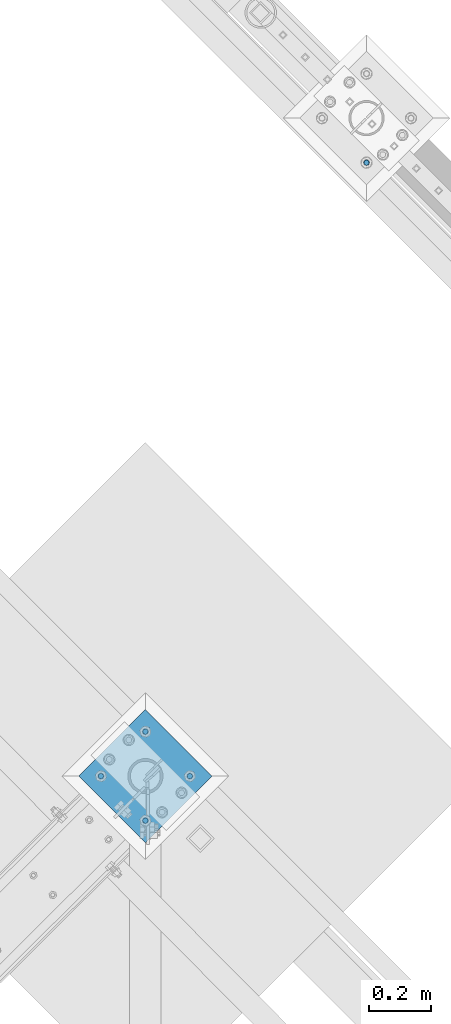
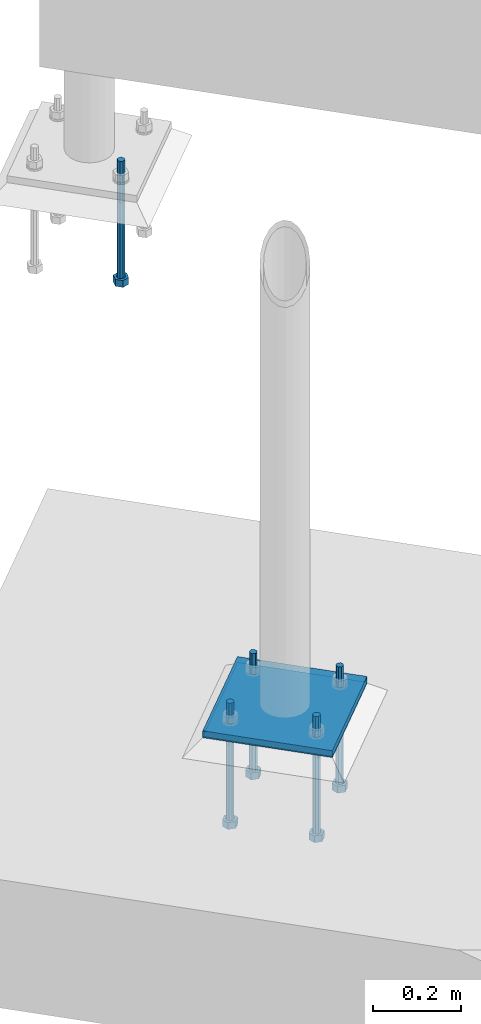
# One storey, part 527 of 975: 7 beams.
"""IFC2X3 building model written with IfcOpenShell, lengths in millimetres."""

import ifcopenshell
import ifcopenshell.guid

model = None  # the IFC model being written
_history = None  # IfcOwnerHistory: only IFC2X3 demands one
_inside = {}  # id of a spatial element -> (the spatial element, [elements in it])
_under = {}  # id of a project, library or spatial element -> (it, [spatial elements below it])
_declared = {}  # id of a project -> (the project, [libraries it declares])
_typed = {}  # id of a type object -> (the type object, [elements of that type])
_made_of = {}  # id of a material, layer set ... -> (it, [elements and type objects made of it])


def new_model(schema):
    """Start an empty IFC model of exactly this schema.

    Asked for "IFC4X3", IfcOpenShell would pick the latest addendum, in which some entities
    have other attributes; the version numbers below select the first issue.
    IFC2X3 requires an IfcOwnerHistory on every rooted entity: one is made here for all.
    """
    global model, _history
    if schema == "IFC4X3":
        model = ifcopenshell.file(schema_version=(4, 3, 0, 0))
    else:
        model = ifcopenshell.file(schema=schema)
    _inside.clear()
    _under.clear()
    _declared.clear()
    _typed.clear()
    _made_of.clear()
    _history = None
    if model.schema == "IFC2X3":
        org = make("IfcOrganization", Name="unknown")
        user = make(
            "IfcPersonAndOrganization",
            ThePerson=make("IfcPerson", FamilyName="unknown"),
            TheOrganization=org,
        )
        app = make(
            "IfcApplication",
            ApplicationDeveloper=org,
            Version="unknown",
            ApplicationFullName="unknown",
            ApplicationIdentifier="unknown",
        )
        _history = make(
            "IfcOwnerHistory",
            OwningUser=user,
            OwningApplication=app,
            ChangeAction="ADDED",
            CreationDate=0,
        )
    return model


def make(cls, **values):
    """One entity of the class cls with the attributes given. An attribute that is None is left unset."""
    return model.create_entity(
        cls, **{name: value for name, value in values.items() if value is not None}
    )


def rooted(cls, **values):
    """An entity with a GlobalId (a new one), such as an element, a storey or a relation."""
    return make(cls, GlobalId=ifcopenshell.guid.new(), OwnerHistory=_history, **values)


def si_unit(unit_type, name, prefix=None):
    """IfcSIUnit, for example si_unit("LENGTHUNIT", "METRE", prefix="MILLI")."""
    return make("IfcSIUnit", UnitType=unit_type, Prefix=prefix, Name=name)


def assignment(units):
    """IfcUnitAssignment: the units of a project."""
    return None if units is None else make("IfcUnitAssignment", Units=units)


def point(xyz):
    """IfcCartesianPoint."""
    return None if xyz is None else make("IfcCartesianPoint", Coordinates=xyz)


def direction(xyz):
    """IfcDirection."""
    return None if xyz is None else make("IfcDirection", DirectionRatios=xyz)


def frame(location, z_axis=None, x_axis=None):
    """IfcAxis2Placement3D, a coordinate frame: its origin and axes. An axis left out is left unset."""
    return make(
        "IfcAxis2Placement3D",
        Location=point(location),
        Axis=direction(z_axis),
        RefDirection=direction(x_axis),
    )


def origin_with_axes():
    """The frame at (0, 0, 0) with the z axis (0, 0, 1) and the x axis (1, 0, 0) written out."""
    return frame((0.0, 0.0, 0.0), z_axis=(0.0, 0.0, 1.0), x_axis=(1.0, 0.0, 0.0))


def place(relative_to, where):
    """IfcLocalPlacement: puts the frame where relative to a parent placement (None: the world)."""
    return make(
        "IfcLocalPlacement", PlacementRelTo=relative_to, RelativePlacement=where
    )


def context(
    kind, dimensions, precision=None, world=None, true_north=None, identifier=None
):
    """IfcGeometricRepresentationContext, for example the 3D "Model" context."""
    return make(
        "IfcGeometricRepresentationContext",
        ContextIdentifier=identifier,
        ContextType=kind,
        CoordinateSpaceDimension=dimensions,
        Precision=precision,
        WorldCoordinateSystem=world,
        TrueNorth=true_north,
    )


def subcontext(parent, identifier, kind, view, scale=None):
    """IfcGeometricRepresentationSubContext, for example "Body" below "Model"."""
    return make(
        "IfcGeometricRepresentationSubContext",
        ContextIdentifier=identifier,
        ContextType=kind,
        ParentContext=parent,
        TargetScale=scale,
        TargetView=view,
    )


def project(units=None, contexts=None):
    """IfcProject with its units and contexts."""
    return rooted(
        "IfcProject",
        Name="project",
        RepresentationContexts=contexts,
        UnitsInContext=assignment(units),
    )


def spatial(cls, under=None, at=None, **own):
    """A site, building, storey or space (cls), placed at a placement, below another one or the project."""
    s = rooted(cls, ObjectPlacement=at, **own)
    if under is not None:
        _under.setdefault(under.id(), (under, []))[1].append(s)
    return s


def faces_of(points, faces, orient=None, outer=None):
    """IfcFace entities. A face is a list of loops; a loop is a list of indices into points, from 0.

    orient and outer hold one flag for each loop. By default every Orientation is true, the
    first loop of a face is its IfcFaceOuterBound and the others are IfcFaceBound.
    """
    made = []
    for i, loops in enumerate(faces):
        bounds = []
        for j, loop in enumerate(loops):
            is_outer = j == 0 if outer is None else outer[i][j]
            bounds.append(
                make(
                    "IfcFaceOuterBound" if is_outer else "IfcFaceBound",
                    Bound=make("IfcPolyLoop", Polygon=[points[k] for k in loop]),
                    Orientation=True if orient is None else orient[i][j],
                )
            )
        made.append(make("IfcFace", Bounds=bounds))
    return made


def faceted_brep(points, faces, orient=None, outer=None, voids=None):
    """IfcFacetedBrep: a solid bounded by flat faces; with voids (closed shells), ...WithVoids."""
    shared = [point(p) for p in points]
    hull = make("IfcClosedShell", CfsFaces=faces_of(shared, faces, orient, outer))
    if voids is None:
        return make("IfcFacetedBrep", Outer=hull)
    return make(
        "IfcFacetedBrepWithVoids",
        Outer=hull,
        Voids=[
            make(cls, CfsFaces=faces_of(shared, fs, o, b)) for cls, fs, o, b in voids
        ],
    )


def shape(context_of_items, identifier, shape_type, items):
    """IfcShapeRepresentation: the items that make up one representation, for example the "Body"."""
    return make(
        "IfcShapeRepresentation",
        ContextOfItems=context_of_items,
        RepresentationIdentifier=identifier,
        RepresentationType=shape_type,
        Items=items,
    )


def material(Name=None, Category=None):
    """IfcMaterial."""
    return make("IfcMaterial", Name=Name, Category=Category)


def made_of(thing, what):
    """Note that an element or type object is made of a material, layer set ...; save() writes the relation."""
    if what is not None:
        _made_of.setdefault(what.id(), (what, []))[1].append(thing)
    return thing


def type_object(cls, material=None, **own):
    """A type object (cls), such as IfcWallType, which elements share."""
    return made_of(rooted(cls, **own), material)


def element(
    cls,
    number,
    at=None,
    inside=None,
    cuts=None,
    type_object=None,
    material=None,
    context=None,
    identifier="Body",
    shape_type=None,
    held_by="IfcProductDefinitionShape",
    body=None,
    shapes=None,
    **own,
):
    """One element of the class cls, such as IfcWall. Its Tag is "e" and its number.

    at: its placement. inside: the storey or other place that contains it. cuts: it is an
    opening in that element (IfcRelVoidsElement). A single representation is given by context,
    identifier, shape_type and body (its items); several are given by shapes. held_by: the class
    of the entity that holds the representations. save() writes the other relations.
    """
    e = rooted(cls, Tag="e%d" % number, ObjectPlacement=at, **own)
    if body is not None:
        shapes = [shape(context, identifier, shape_type, body)]
    if shapes is not None:
        e.Representation = make(held_by, Representations=shapes)
    if inside is not None:
        _inside.setdefault(inside.id(), (inside, []))[1].append(e)
    if cuts is not None:
        rooted(
            "IfcRelVoidsElement", RelatingBuildingElement=cuts, RelatedOpeningElement=e
        )
    if type_object is not None:
        _typed.setdefault(type_object.id(), (type_object, []))[1].append(e)
    return made_of(e, material)


def aggregate(whole, parts):
    """IfcRelAggregates: a whole, such as a stair, and the parts it consists of."""
    return rooted("IfcRelAggregates", RelatingObject=whole, RelatedObjects=parts)


def save(model, path):
    """Write the relations noted so far, then the file.

    IfcRelAggregates (storeys below a building ...), IfcRelContainedInSpatialStructure (elements
    in a storey), IfcRelDefinesByType, IfcRelAssociatesMaterial and IfcRelDeclares: one each for
    every whole, place, type object, material and project.
    """
    for whole, parts in _under.values():
        aggregate(whole, parts)
    for where, things in _inside.values():
        rooted(
            "IfcRelContainedInSpatialStructure",
            RelatedElements=things,
            RelatingStructure=where,
        )
    for kind, things in _typed.values():
        rooted("IfcRelDefinesByType", RelatedObjects=things, RelatingType=kind)
    for what, things in _made_of.values():
        rooted("IfcRelAssociatesMaterial", RelatedObjects=things, RelatingMaterial=what)
    for by, libraries in _declared.values():
        rooted("IfcRelDeclares", RelatingContext=by, RelatedDefinitions=libraries)
    model.write(path)


model = new_model("IFC2X3")

# Units and contexts
model_context = context("Model", 3, precision=1e-05, world=origin_with_axes())
body_context = subcontext(model_context, "Body", "Model", "MODEL_VIEW")
ifc_project = project(units=[si_unit("LENGTHUNIT", "METRE", prefix="MILLI"), si_unit("AREAUNIT", "SQUARE_METRE"), si_unit("VOLUMEUNIT", "CUBIC_METRE"), si_unit("MASSUNIT", "GRAM", prefix="KILO"), si_unit("TIMEUNIT", "SECOND"), si_unit("PLANEANGLEUNIT", "RADIAN"), si_unit("SOLIDANGLEUNIT", "STERADIAN"), si_unit("THERMODYNAMICTEMPERATUREUNIT", "DEGREE_CELSIUS"), si_unit("LUMINOUSINTENSITYUNIT", "LUMEN")], contexts=[model_context])

# Site, building, storey
site_placement = place(None, origin_with_axes())
site = spatial("IfcSite", under=ifc_project, at=site_placement, CompositionType="ELEMENT")
building_placement = place(site_placement, origin_with_axes())
building = spatial("IfcBuilding", under=site, at=building_placement, Name="Undefined", CompositionType="ELEMENT")
storey_placement = place(building_placement, origin_with_axes())
storey = spatial("IfcBuildingStorey", under=building, at=storey_placement, Name="Undefined", CompositionType="ELEMENT", Elevation=0.0)

# Beams
ifc_material_1 = material(Name="STEEL/A36")
beam_type_1 = type_object("IfcBeamType", PredefinedType="NOTDEFINED")
beam_1_placement = place(storey_placement, frame((29940.0630734527, 15856.1369265472, -257.175000000002), z_axis=(-0.707106781186548, -0.707106781186548, 0.0), x_axis=(-0.707106781186601, 0.707106781186494, 2.36468622460961e-14)))
element("IfcBeam", 1, at=beam_1_placement, inside=storey, type_object=beam_type_1, material=ifc_material_1, Name="PLATE", context=body_context, shape_type="Brep", body=[
    faceted_brep([(0.0, 9.52499999999964, -152.4), (0.0, 9.52499999999964, 152.4), (304.799999999152, 9.52499999999964, 152.4), (304.799999999152, 9.52499999999964, -152.4), (0.0, -9.52499999999964, 152.4), (304.799999999152, -9.52499999999964, 152.4), (0.0, -9.52499999999964, -152.4), (304.799999999152, -9.52499999999964, -152.4)], [[[0, 1, 2, 3]], [[1, 4, 5, 2]], [[4, 6, 7, 5]], [[6, 0, 3, 7]], [[5, 7, 3, 2]], [[6, 4, 1, 0]]]),
])
ifc_material_2 = material(Name="STEEL/F1554-36")
beam_type_2 = type_object("IfcBeamType", PredefinedType="NOTDEFINED")
beam_2_placement = place(storey_placement, frame((30546.675001079, 17945.8784053001, -304.799999999999), z_axis=(0.707106781186548, 0.707106781186548, 0.0), x_axis=(0.0, 0.0, -1.0)))
element("IfcBeam", 2, at=beam_2_placement, inside=storey, type_object=beam_type_2, material=ifc_material_2, Name="HEADED_ANCHOR_BOLT", context=body_context, shape_type="Brep", body=[
    faceted_brep([(209.543749999999, -9.13000011446275, 15.8100004196049), (209.543749999999, -18.2600002288382, 4.72937244921923e-11), (228.593749999998, -18.2600002288382, 4.72937244921923e-11), (228.593749999998, -9.13000011446275, 15.8100004196049), (209.543749999999, 9.13000011438271, 15.8100004195576), (228.593749999998, 9.13000011438271, 15.8100004195576), (209.543749999999, 18.2600002288382, -4.72937244921923e-11), (228.593749999998, 18.2600002288382, -4.72937244921923e-11), (209.543749999999, 9.13000011446275, -15.8100004196049), (228.593749999998, 9.13000011446275, -15.8100004196049), (209.543749999999, -9.13000011438271, -15.8100004195576), (228.593749999998, -9.13000011438271, -15.8100004195576), (209.543749999999, -4.4776800552936, 9.29799844178979), (209.543749999999, -8.068500660469, 6.43441456491473), (209.543749999999, -10.0612557561763, 2.2964159705416), (209.543749999999, -10.0612557561617, -2.29641597048976), (209.543749999999, -8.0685006604399, -6.4344145648729), (209.543749999999, -4.47768005524995, -9.29799844176705), (209.543749999999, 2.91038304567337e-11, -10.3199996948015), (209.543749999999, 4.4776800552936, -9.29799844178979), (209.543749999999, 8.068500660469, -6.43441456491473), (209.543749999999, 10.0612557561763, -2.2964159705416), (209.543749999999, 10.0612557561617, 2.29641597048976), (209.543749999999, 8.0685006604399, 6.4344145648729), (209.543749999999, 4.47768005524995, 9.29799844176705), (209.543749999999, -2.91038304567337e-11, 10.3199996948015), (228.593749999998, -2.91038304567337e-11, 10.3199996948015), (228.593749999998, -4.4776800552936, 9.29799844178979), (228.593749999998, -8.068500660469, 6.43441456491473), (228.593749999998, -10.0612557561763, 2.2964159705416), (228.593749999998, -10.0612557561617, -2.29641597048976), (228.593749999998, -8.0685006604399, -6.4344145648729), (228.593749999998, -4.47768005524995, -9.29799844176705), (228.593749999998, 2.91038304567337e-11, -10.3199996948015), (228.593749999998, 4.4776800552936, -9.29799844178979), (228.593749999998, 8.068500660469, -6.43441456491473), (228.593749999998, 10.0612557561763, -2.2964159705416), (228.593749999998, 10.0612557561617, 2.29641597048976), (228.593749999998, 8.0685006604399, 6.4344145648729), (228.593749999998, 4.47768005524995, 9.29799844176705), (0.0, -6.73519209080223, 6.73519209080186), (0.0, -9.52499999999964, 0.0), (228.6, -9.52500000000146, 0.0), (228.6, -6.73519209080405, 6.73519209080223), (-9.87109982941227e-13, -1.20792265079217e-13, 9.52499961853027), (228.6, 0.0, 9.52499999999964), (0.0, 6.73519209080223, 6.73519209080186), (228.6, 6.73519209080405, 6.73519209080223), (0.0, 9.52499999999964, 0.0), (228.6, 9.52500000000146, 0.0), (0.0, 6.73519209080223, -6.73519209080186), (228.6, 6.73519209080405, -6.73519209080223), (2.95075507493764e-12, -1.20792265079217e-13, -9.52499961853027), (228.6, 0.0, -9.52499999999964), (-114.297914995421, -6.36396103067818, 6.36396103068091), (-114.297914995421, -2.18278728425503e-11, 8.99999999997999), (-114.297914995421, 6.36396103064908, 6.36396103064817), (-114.297914995421, 8.99999999997817, -2.27373675443232e-11), (-114.297914995421, 6.36396103067818, -6.36396103068091), (-114.297914995421, 2.18278728425503e-11, -8.99999999997999), (-114.297914995421, -6.36396103064908, -6.36396103064817), (-114.297914995421, -8.99999999997817, 2.27373675443232e-11), (0.0149743263646087, 6.36396103067818, -6.36396103067909), (0.0149743263646087, 0.0, -9.0), (0.0149743263646087, -6.36396103067818, -6.36396103067909), (0.0149743263987148, -8.9999995411581, -1.00796984270346e-06), (0.0149743263646087, -6.36396103067818, 6.36396103067909), (0.0149743263646087, 0.0, 9.0), (0.0149743263646087, 6.36396103067818, 6.36396103067909), (0.0149743263987148, 9.0000004588419, -1.00796984270346e-06), (0.0, -6.73519209080223, -6.73519209080186), (228.6, -6.73519209080405, -6.73519209080223)], [[[0, 1, 2, 3]], [[4, 0, 3, 5]], [[6, 4, 5, 7]], [[8, 6, 7, 9]], [[10, 8, 9, 11]], [[0, 4, 6, 8, 10, 1], [12, 13, 14, 15, 16, 17, 18, 19, 20, 21, 22, 23, 24, 25]], [[12, 25, 26, 27]], [[13, 12, 27, 28]], [[14, 13, 28, 29]], [[15, 14, 29, 30]], [[16, 15, 30, 31]], [[17, 16, 31, 32]], [[18, 17, 32, 33]], [[19, 18, 33, 34]], [[20, 19, 34, 35]], [[21, 20, 35, 36]], [[22, 21, 36, 37]], [[23, 22, 37, 38]], [[24, 23, 38, 39]], [[25, 24, 39, 26]], [[9, 7, 5, 3, 2, 11], [38, 37, 36, 35, 34, 33, 32, 31, 30, 29, 28, 27, 26, 39]], [[1, 10, 11, 2]], [[40, 41, 42, 43]], [[44, 40, 43, 45]], [[46, 44, 45, 47]], [[48, 46, 47, 49]], [[50, 48, 49, 51]], [[52, 50, 51, 53]], [[54, 55, 56, 57, 58, 59, 60, 61]], [[59, 58, 62, 63]], [[60, 59, 63, 64]], [[61, 60, 64, 65]], [[54, 61, 65, 66]], [[55, 54, 66, 67]], [[56, 55, 67, 68]], [[57, 56, 68, 69]], [[58, 57, 69, 62]], [[40, 44, 46, 48, 50, 52, 70, 41], [68, 67, 66, 65, 64, 63, 62, 69]], [[41, 70, 71, 42]], [[53, 51, 49, 47, 45, 43, 42, 71]], [[70, 52, 53, 71]]]),
])
beam_3_placement = place(storey_placement, frame((29832.300001079, 16107.5840947003, -304.794708331233), z_axis=(-0.707106781186601, 0.707106781186494, 2.36468622460961e-14), x_axis=(0.0, 0.0, -1.0)))
element("IfcBeam", 3, at=beam_3_placement, inside=storey, type_object=beam_type_2, material=ifc_material_2, Name="HEADED_ANCHOR_BOLT", context=body_context, shape_type="Brep", body=[
    faceted_brep([(210.349041668767, -9.13000011445183, 15.8100004196131), (210.349041668767, -18.2600002288636, 2.5465851649642e-11), (229.399041668767, -18.2600002288636, 2.5465851649642e-11), (229.399041668767, -9.13000011445183, 15.8100004196131), (210.349041668767, 9.13000011440818, 15.8100004195894), (229.399041668767, 9.13000011440818, 15.8100004195894), (210.349041668767, 18.26000022886, -2.18278728425503e-11), (229.399041668767, 18.26000022886, -2.18278728425503e-11), (210.349041668767, 9.13000011444819, -15.8100004196076), (229.399041668767, 9.13000011444819, -15.8100004196076), (210.349041668767, -9.13000011441545, -15.8100004195876), (229.399041668767, -9.13000011441545, -15.8100004195876), (210.349041668767, -4.47768005528997, 9.29799844179615), (210.349041668767, -8.06850066047264, 6.43441456491382), (210.349041668767, -10.0612557561872, 2.2964159705316), (210.349041668767, -10.0612557561799, -2.29641597050431), (210.349041668767, -8.06850066045808, -6.43441456488472), (210.349041668767, -4.47768005526814, -9.2979984417816), (210.349041668767, 1.09139364212751e-11, -10.3199996948097), (210.349041668767, 4.47768005528997, -9.29799844179433), (210.349041668767, 8.06850066047264, -6.43441456491018), (210.349041668767, 10.0612557561799, -2.29641597052978), (210.349041668767, 10.0612557561763, 2.29641597051159), (210.349041668767, 8.06850066045808, 6.43441456489199), (210.349041668767, 4.47768005526086, 9.29799844178342), (210.349041668767, -1.09139364212751e-11, 10.3199996948151), (229.399041668767, -1.09139364212751e-11, 10.3199996948151), (229.399041668767, -4.47768005528997, 9.29799844179615), (229.399041668767, -8.06850066047264, 6.43441456491382), (229.399041668767, -10.0612557561872, 2.2964159705316), (229.399041668767, -10.0612557561799, -2.29641597050431), (229.399041668767, -8.06850066045808, -6.43441456488472), (229.399041668767, -4.47768005526814, -9.2979984417816), (229.399041668767, 1.09139364212751e-11, -10.3199996948097), (229.399041668767, 4.47768005528997, -9.29799844179433), (229.399041668767, 8.06850066047264, -6.43441456491018), (229.399041668767, 10.0612557561799, -2.29641597052978), (229.399041668767, 10.0612557561763, 2.29641597051159), (229.399041668767, 8.06850066045808, 6.43441456489199), (229.399041668767, 4.47768005526086, 9.29799844178342), (0.0, -6.73519209080223, 6.73519209080186), (0.0, -9.52499999999964, 0.0), (228.605291668766, -9.52499999999054, 1.45519152283669e-11), (228.605291668766, -6.73519209080405, 6.73519209080405), (-9.87109982941227e-13, -1.20792265079217e-13, 9.52499961853027), (228.605291668766, -1.09139364212751e-11, 9.52499999999054), (0.0, 6.73519209080223, 6.73519209080186), (228.605291668766, 6.73519209078586, 6.73519209078768), (0.0, 9.52499999999964, 0.0), (228.605291668766, 9.52499999999054, -9.09494701772928e-12), (0.0, 6.73519209080223, -6.73519209080186), (228.605291668766, 6.73519209080041, -6.73519209080223), (2.95075507493764e-12, -1.20792265079217e-13, -9.52499961853027), (228.605291668766, 1.09139364212751e-11, -9.52499999998508), (-114.294672089865, -6.36396103028892, 6.36396103068546), (-114.29460082623, -1.09139364212751e-11, 8.99999999999091), (-114.294529562594, 6.36396103026709, 6.36396103066909), (-114.29450004423, 8.99999999943611, -9.09494701772928e-12), (-114.294529562594, 6.36396103028528, -6.36396103067455), (-114.29460082623, 1.09139364212751e-11, -8.99999999998909), (-114.294672089865, -6.36396103027437, -6.36396103066363), (-114.29470160823, -8.99999999943611, 1.45519152283669e-11), (0.00536293275933986, 6.36268110000674, -6.36396103067818), (0.00529166912366463, -0.00127993026762852, -8.99999999998545), (0.00522040548793257, -6.36524096055291, -6.36396103066181), (0.00519088712354687, -9.00127992971102, 1.45519152283669e-11), (0.00522040548793257, -6.36524096056746, 6.36396103068182), (0.00529166912366463, -0.00127993029309437, 8.99999999999454), (0.00536293275933986, 6.36268109998855, 6.36396103066545), (0.00539245112372555, 8.99872006915029, -9.09494701772928e-12), (0.0, -6.73519209080223, -6.73519209080186), (228.605291668766, -6.73519209078586, -6.7351920907804)], [[[0, 1, 2, 3]], [[4, 0, 3, 5]], [[6, 4, 5, 7]], [[8, 6, 7, 9]], [[10, 8, 9, 11]], [[0, 4, 6, 8, 10, 1], [12, 13, 14, 15, 16, 17, 18, 19, 20, 21, 22, 23, 24, 25]], [[12, 25, 26, 27]], [[13, 12, 27, 28]], [[14, 13, 28, 29]], [[15, 14, 29, 30]], [[16, 15, 30, 31]], [[17, 16, 31, 32]], [[18, 17, 32, 33]], [[19, 18, 33, 34]], [[20, 19, 34, 35]], [[21, 20, 35, 36]], [[22, 21, 36, 37]], [[23, 22, 37, 38]], [[24, 23, 38, 39]], [[25, 24, 39, 26]], [[9, 7, 5, 3, 2, 11], [38, 37, 36, 35, 34, 33, 32, 31, 30, 29, 28, 27, 26, 39]], [[1, 10, 11, 2]], [[40, 41, 42, 43]], [[44, 40, 43, 45]], [[46, 44, 45, 47]], [[48, 46, 47, 49]], [[50, 48, 49, 51]], [[52, 50, 51, 53]], [[54, 55, 56, 57, 58, 59, 60, 61]], [[59, 58, 62, 63]], [[60, 59, 63, 64]], [[61, 60, 64, 65]], [[54, 61, 65, 66]], [[55, 54, 66, 67]], [[56, 55, 67, 68]], [[57, 56, 68, 69]], [[58, 57, 69, 62]], [[40, 44, 46, 48, 50, 52, 70, 41], [68, 67, 66, 65, 64, 63, 62, 69]], [[41, 70, 71, 42]], [[53, 51, 49, 47, 45, 43, 42, 71]], [[70, 52, 53, 71]]]),
])
beam_4_placement = place(storey_placement, frame((29688.6159053001, 15963.899998921, -304.794708331233), z_axis=(0.707106781186513, -0.707106781186582, 3.1377567211166e-14), x_axis=(0.0, 0.0, -1.0)))
element("IfcBeam", 4, at=beam_4_placement, inside=storey, type_object=beam_type_2, material=ifc_material_2, Name="HEADED_ANCHOR_BOLT", context=body_context, shape_type="Brep", body=[
    faceted_brep([(210.349041668767, -9.13000011445183, 15.8100004196131), (210.349041668767, -18.2600002288636, 2.5465851649642e-11), (229.399041668767, -18.2600002288636, 2.5465851649642e-11), (229.399041668767, -9.13000011445183, 15.8100004196131), (210.349041668767, 9.13000011440818, 15.8100004195894), (229.399041668767, 9.13000011440818, 15.8100004195894), (210.349041668767, 18.26000022886, -2.18278728425503e-11), (229.399041668767, 18.26000022886, -2.18278728425503e-11), (210.349041668767, 9.13000011444819, -15.8100004196076), (229.399041668767, 9.13000011444819, -15.8100004196076), (210.349041668767, -9.13000011441545, -15.8100004195876), (229.399041668767, -9.13000011441545, -15.8100004195876), (210.349041668767, -4.47768005528997, 9.29799844179615), (210.349041668767, -8.06850066047264, 6.43441456491382), (210.349041668767, -10.0612557561872, 2.2964159705316), (210.349041668767, -10.0612557561799, -2.29641597050431), (210.349041668767, -8.06850066045808, -6.43441456488472), (210.349041668767, -4.47768005526814, -9.2979984417816), (210.349041668767, 1.09139364212751e-11, -10.3199996948097), (210.349041668767, 4.47768005528997, -9.29799844179433), (210.349041668767, 8.06850066047264, -6.43441456491018), (210.349041668767, 10.0612557561799, -2.29641597052978), (210.349041668767, 10.0612557561763, 2.29641597051159), (210.349041668767, 8.06850066045808, 6.43441456489199), (210.349041668767, 4.47768005526086, 9.29799844178342), (210.349041668767, -1.09139364212751e-11, 10.3199996948151), (229.399041668767, -1.09139364212751e-11, 10.3199996948151), (229.399041668767, -4.47768005528997, 9.29799844179615), (229.399041668767, -8.06850066047264, 6.43441456491382), (229.399041668767, -10.0612557561872, 2.2964159705316), (229.399041668767, -10.0612557561799, -2.29641597050431), (229.399041668767, -8.06850066045808, -6.43441456488472), (229.399041668767, -4.47768005526814, -9.2979984417816), (229.399041668767, 1.09139364212751e-11, -10.3199996948097), (229.399041668767, 4.47768005528997, -9.29799844179433), (229.399041668767, 8.06850066047264, -6.43441456491018), (229.399041668767, 10.0612557561799, -2.29641597052978), (229.399041668767, 10.0612557561763, 2.29641597051159), (229.399041668767, 8.06850066045808, 6.43441456489199), (229.399041668767, 4.47768005526086, 9.29799844178342), (0.0, -6.73519209080223, 6.73519209080186), (0.0, -9.52499999999964, 0.0), (228.605291668766, -9.52499999999054, 1.45519152283669e-11), (228.605291668766, -6.73519209080405, 6.73519209080405), (-9.87109982941227e-13, -1.20792265079217e-13, 9.52499961853027), (228.605291668766, -1.09139364212751e-11, 9.52499999999054), (0.0, 6.73519209080223, 6.73519209080186), (228.605291668766, 6.73519209078586, 6.73519209078768), (0.0, 9.52499999999964, 0.0), (228.605291668766, 9.52499999999054, -9.09494701772928e-12), (0.0, 6.73519209080223, -6.73519209080186), (228.605291668766, 6.73519209080041, -6.73519209080223), (2.95075507493764e-12, -1.20792265079217e-13, -9.52499961853027), (228.605291668766, 1.09139364212751e-11, -9.52499999998508), (-114.294672089865, -6.36396103028892, 6.36396103068546), (-114.29460082623, -1.09139364212751e-11, 8.99999999999091), (-114.294529562594, 6.36396103026709, 6.36396103066909), (-114.29450004423, 8.99999999943611, -9.09494701772928e-12), (-114.294529562594, 6.36396103028528, -6.36396103067455), (-114.29460082623, 1.09139364212751e-11, -8.99999999998909), (-114.294672089865, -6.36396103027437, -6.36396103066363), (-114.29470160823, -8.99999999943611, 1.45519152283669e-11), (0.00536293275933986, 6.36268110000674, -6.36396103067818), (0.00529166912366463, -0.00127993026762852, -8.99999999998545), (0.00522040548793257, -6.36524096055291, -6.36396103066181), (0.00519088712354687, -9.00127992971102, 1.45519152283669e-11), (0.00522040548793257, -6.36524096056746, 6.36396103068182), (0.00529166912366463, -0.00127993029309437, 8.99999999999454), (0.00536293275933986, 6.36268109998855, 6.36396103066545), (0.00539245112372555, 8.99872006915029, -9.09494701772928e-12), (0.0, -6.73519209080223, -6.73519209080186), (228.605291668766, -6.73519209078586, -6.7351920907804)], [[[0, 1, 2, 3]], [[4, 0, 3, 5]], [[6, 4, 5, 7]], [[8, 6, 7, 9]], [[10, 8, 9, 11]], [[0, 4, 6, 8, 10, 1], [12, 13, 14, 15, 16, 17, 18, 19, 20, 21, 22, 23, 24, 25]], [[12, 25, 26, 27]], [[13, 12, 27, 28]], [[14, 13, 28, 29]], [[15, 14, 29, 30]], [[16, 15, 30, 31]], [[17, 16, 31, 32]], [[18, 17, 32, 33]], [[19, 18, 33, 34]], [[20, 19, 34, 35]], [[21, 20, 35, 36]], [[22, 21, 36, 37]], [[23, 22, 37, 38]], [[24, 23, 38, 39]], [[25, 24, 39, 26]], [[9, 7, 5, 3, 2, 11], [38, 37, 36, 35, 34, 33, 32, 31, 30, 29, 28, 27, 26, 39]], [[1, 10, 11, 2]], [[40, 41, 42, 43]], [[44, 40, 43, 45]], [[46, 44, 45, 47]], [[48, 46, 47, 49]], [[50, 48, 49, 51]], [[52, 50, 51, 53]], [[54, 55, 56, 57, 58, 59, 60, 61]], [[59, 58, 62, 63]], [[60, 59, 63, 64]], [[61, 60, 64, 65]], [[54, 61, 65, 66]], [[55, 54, 66, 67]], [[56, 55, 67, 68]], [[57, 56, 68, 69]], [[58, 57, 69, 62]], [[40, 44, 46, 48, 50, 52, 70, 41], [68, 67, 66, 65, 64, 63, 62, 69]], [[41, 70, 71, 42]], [[53, 51, 49, 47, 45, 43, 42, 71]], [[70, 52, 53, 71]]]),
])
beam_5_placement = place(storey_placement, frame((29832.300001079, 15820.2159031418, -304.794708331233), z_axis=(0.707106781186513, -0.707106781186582, 3.1377567211166e-14), x_axis=(0.0, 0.0, -1.0)))
element("IfcBeam", 5, at=beam_5_placement, inside=storey, type_object=beam_type_2, material=ifc_material_2, Name="HEADED_ANCHOR_BOLT", context=body_context, shape_type="Brep", body=[
    faceted_brep([(210.349041668767, -9.13000011445183, 15.8100004196131), (210.349041668767, -18.2600002288636, 2.5465851649642e-11), (229.399041668767, -18.2600002288636, 2.5465851649642e-11), (229.399041668767, -9.13000011445183, 15.8100004196131), (210.349041668767, 9.13000011440818, 15.8100004195894), (229.399041668767, 9.13000011440818, 15.8100004195894), (210.349041668767, 18.26000022886, -2.18278728425503e-11), (229.399041668767, 18.26000022886, -2.18278728425503e-11), (210.349041668767, 9.13000011444819, -15.8100004196076), (229.399041668767, 9.13000011444819, -15.8100004196076), (210.349041668767, -9.13000011441545, -15.8100004195876), (229.399041668767, -9.13000011441545, -15.8100004195876), (210.349041668767, -4.47768005528997, 9.29799844179615), (210.349041668767, -8.06850066047264, 6.43441456491382), (210.349041668767, -10.0612557561872, 2.2964159705316), (210.349041668767, -10.0612557561799, -2.29641597050431), (210.349041668767, -8.06850066045808, -6.43441456488472), (210.349041668767, -4.47768005526814, -9.2979984417816), (210.349041668767, 1.09139364212751e-11, -10.3199996948097), (210.349041668767, 4.47768005528997, -9.29799844179433), (210.349041668767, 8.06850066047264, -6.43441456491018), (210.349041668767, 10.0612557561799, -2.29641597052978), (210.349041668767, 10.0612557561763, 2.29641597051159), (210.349041668767, 8.06850066045808, 6.43441456489199), (210.349041668767, 4.47768005526086, 9.29799844178342), (210.349041668767, -1.09139364212751e-11, 10.3199996948151), (229.399041668767, -1.09139364212751e-11, 10.3199996948151), (229.399041668767, -4.47768005528997, 9.29799844179615), (229.399041668767, -8.06850066047264, 6.43441456491382), (229.399041668767, -10.0612557561872, 2.2964159705316), (229.399041668767, -10.0612557561799, -2.29641597050431), (229.399041668767, -8.06850066045808, -6.43441456488472), (229.399041668767, -4.47768005526814, -9.2979984417816), (229.399041668767, 1.09139364212751e-11, -10.3199996948097), (229.399041668767, 4.47768005528997, -9.29799844179433), (229.399041668767, 8.06850066047264, -6.43441456491018), (229.399041668767, 10.0612557561799, -2.29641597052978), (229.399041668767, 10.0612557561763, 2.29641597051159), (229.399041668767, 8.06850066045808, 6.43441456489199), (229.399041668767, 4.47768005526086, 9.29799844178342), (0.0, -6.73519209080223, 6.73519209080186), (0.0, -9.52499999999964, 0.0), (228.605291668766, -9.52499999999054, 1.45519152283669e-11), (228.605291668766, -6.73519209080405, 6.73519209080405), (-9.87109982941227e-13, -1.20792265079217e-13, 9.52499961853027), (228.605291668766, -1.09139364212751e-11, 9.52499999999054), (0.0, 6.73519209080223, 6.73519209080186), (228.605291668766, 6.73519209078586, 6.73519209078768), (0.0, 9.52499999999964, 0.0), (228.605291668766, 9.52499999999054, -9.09494701772928e-12), (0.0, 6.73519209080223, -6.73519209080186), (228.605291668766, 6.73519209080041, -6.73519209080223), (2.95075507493764e-12, -1.20792265079217e-13, -9.52499961853027), (228.605291668766, 1.09139364212751e-11, -9.52499999998508), (-114.294672089865, -6.36396103028892, 6.36396103068546), (-114.29460082623, -1.09139364212751e-11, 8.99999999999091), (-114.294529562594, 6.36396103026709, 6.36396103066909), (-114.29450004423, 8.99999999943611, -9.09494701772928e-12), (-114.294529562594, 6.36396103028528, -6.36396103067455), (-114.29460082623, 1.09139364212751e-11, -8.99999999998909), (-114.294672089865, -6.36396103027437, -6.36396103066363), (-114.29470160823, -8.99999999943611, 1.45519152283669e-11), (0.00536293275933986, 6.36268110000674, -6.36396103067818), (0.00529166912366463, -0.00127993026762852, -8.99999999998545), (0.00522040548793257, -6.36524096055291, -6.36396103066181), (0.00519088712354687, -9.00127992971102, 1.45519152283669e-11), (0.00522040548793257, -6.36524096056746, 6.36396103068182), (0.00529166912366463, -0.00127993029309437, 8.99999999999454), (0.00536293275933986, 6.36268109998855, 6.36396103066545), (0.00539245112372555, 8.99872006915029, -9.09494701772928e-12), (0.0, -6.73519209080223, -6.73519209080186), (228.605291668766, -6.73519209078586, -6.7351920907804)], [[[0, 1, 2, 3]], [[4, 0, 3, 5]], [[6, 4, 5, 7]], [[8, 6, 7, 9]], [[10, 8, 9, 11]], [[0, 4, 6, 8, 10, 1], [12, 13, 14, 15, 16, 17, 18, 19, 20, 21, 22, 23, 24, 25]], [[12, 25, 26, 27]], [[13, 12, 27, 28]], [[14, 13, 28, 29]], [[15, 14, 29, 30]], [[16, 15, 30, 31]], [[17, 16, 31, 32]], [[18, 17, 32, 33]], [[19, 18, 33, 34]], [[20, 19, 34, 35]], [[21, 20, 35, 36]], [[22, 21, 36, 37]], [[23, 22, 37, 38]], [[24, 23, 38, 39]], [[25, 24, 39, 26]], [[9, 7, 5, 3, 2, 11], [38, 37, 36, 35, 34, 33, 32, 31, 30, 29, 28, 27, 26, 39]], [[1, 10, 11, 2]], [[40, 41, 42, 43]], [[44, 40, 43, 45]], [[46, 44, 45, 47]], [[48, 46, 47, 49]], [[50, 48, 49, 51]], [[52, 50, 51, 53]], [[54, 55, 56, 57, 58, 59, 60, 61]], [[59, 58, 62, 63]], [[60, 59, 63, 64]], [[61, 60, 64, 65]], [[54, 61, 65, 66]], [[55, 54, 66, 67]], [[56, 55, 67, 68]], [[57, 56, 68, 69]], [[58, 57, 69, 62]], [[40, 44, 46, 48, 50, 52, 70, 41], [68, 67, 66, 65, 64, 63, 62, 69]], [[41, 70, 71, 42]], [[53, 51, 49, 47, 45, 43, 42, 71]], [[70, 52, 53, 71]]]),
])
beam_6_placement = place(storey_placement, frame((29975.9840968578, 15963.899998921, -304.794708331233), z_axis=(-0.707106781186601, 0.707106781186494, 2.36468622460961e-14), x_axis=(0.0, 0.0, -1.0)))
element("IfcBeam", 6, at=beam_6_placement, inside=storey, type_object=beam_type_2, material=ifc_material_2, Name="HEADED_ANCHOR_BOLT", context=body_context, shape_type="Brep", body=[
    faceted_brep([(210.349041668767, -9.13000011445183, 15.8100004196131), (210.349041668767, -18.2600002288636, 2.5465851649642e-11), (229.399041668767, -18.2600002288636, 2.5465851649642e-11), (229.399041668767, -9.13000011445183, 15.8100004196131), (210.349041668767, 9.13000011440818, 15.8100004195894), (229.399041668767, 9.13000011440818, 15.8100004195894), (210.349041668767, 18.26000022886, -2.18278728425503e-11), (229.399041668767, 18.26000022886, -2.18278728425503e-11), (210.349041668767, 9.13000011444819, -15.8100004196076), (229.399041668767, 9.13000011444819, -15.8100004196076), (210.349041668767, -9.13000011441545, -15.8100004195876), (229.399041668767, -9.13000011441545, -15.8100004195876), (210.349041668767, -4.47768005528997, 9.29799844179615), (210.349041668767, -8.06850066047264, 6.43441456491382), (210.349041668767, -10.0612557561872, 2.2964159705316), (210.349041668767, -10.0612557561799, -2.29641597050431), (210.349041668767, -8.06850066045808, -6.43441456488472), (210.349041668767, -4.47768005526814, -9.2979984417816), (210.349041668767, 1.09139364212751e-11, -10.3199996948097), (210.349041668767, 4.47768005528997, -9.29799844179433), (210.349041668767, 8.06850066047264, -6.43441456491018), (210.349041668767, 10.0612557561799, -2.29641597052978), (210.349041668767, 10.0612557561763, 2.29641597051159), (210.349041668767, 8.06850066045808, 6.43441456489199), (210.349041668767, 4.47768005526086, 9.29799844178342), (210.349041668767, -1.09139364212751e-11, 10.3199996948151), (229.399041668767, -1.09139364212751e-11, 10.3199996948151), (229.399041668767, -4.47768005528997, 9.29799844179615), (229.399041668767, -8.06850066047264, 6.43441456491382), (229.399041668767, -10.0612557561872, 2.2964159705316), (229.399041668767, -10.0612557561799, -2.29641597050431), (229.399041668767, -8.06850066045808, -6.43441456488472), (229.399041668767, -4.47768005526814, -9.2979984417816), (229.399041668767, 1.09139364212751e-11, -10.3199996948097), (229.399041668767, 4.47768005528997, -9.29799844179433), (229.399041668767, 8.06850066047264, -6.43441456491018), (229.399041668767, 10.0612557561799, -2.29641597052978), (229.399041668767, 10.0612557561763, 2.29641597051159), (229.399041668767, 8.06850066045808, 6.43441456489199), (229.399041668767, 4.47768005526086, 9.29799844178342), (0.0, -6.73519209080223, 6.73519209080186), (0.0, -9.52499999999964, 0.0), (228.605291668766, -9.52499999999054, 1.45519152283669e-11), (228.605291668766, -6.73519209080405, 6.73519209080405), (-9.87109982941227e-13, -1.20792265079217e-13, 9.52499961853027), (228.605291668766, -1.09139364212751e-11, 9.52499999999054), (0.0, 6.73519209080223, 6.73519209080186), (228.605291668766, 6.73519209078586, 6.73519209078768), (0.0, 9.52499999999964, 0.0), (228.605291668766, 9.52499999999054, -9.09494701772928e-12), (0.0, 6.73519209080223, -6.73519209080186), (228.605291668766, 6.73519209080041, -6.73519209080223), (2.95075507493764e-12, -1.20792265079217e-13, -9.52499961853027), (228.605291668766, 1.09139364212751e-11, -9.52499999998508), (-114.294672089865, -6.36396103028892, 6.36396103068546), (-114.29460082623, -1.09139364212751e-11, 8.99999999999091), (-114.294529562594, 6.36396103026709, 6.36396103066909), (-114.29450004423, 8.99999999943611, -9.09494701772928e-12), (-114.294529562594, 6.36396103028528, -6.36396103067455), (-114.29460082623, 1.09139364212751e-11, -8.99999999998909), (-114.294672089865, -6.36396103027437, -6.36396103066363), (-114.29470160823, -8.99999999943611, 1.45519152283669e-11), (0.00536293275933986, 6.36268110000674, -6.36396103067818), (0.00529166912366463, -0.00127993026762852, -8.99999999998545), (0.00522040548793257, -6.36524096055291, -6.36396103066181), (0.00519088712354687, -9.00127992971102, 1.45519152283669e-11), (0.00522040548793257, -6.36524096056746, 6.36396103068182), (0.00529166912366463, -0.00127993029309437, 8.99999999999454), (0.00536293275933986, 6.36268109998855, 6.36396103066545), (0.00539245112372555, 8.99872006915029, -9.09494701772928e-12), (0.0, -6.73519209080223, -6.73519209080186), (228.605291668766, -6.73519209078586, -6.7351920907804)], [[[0, 1, 2, 3]], [[4, 0, 3, 5]], [[6, 4, 5, 7]], [[8, 6, 7, 9]], [[10, 8, 9, 11]], [[0, 4, 6, 8, 10, 1], [12, 13, 14, 15, 16, 17, 18, 19, 20, 21, 22, 23, 24, 25]], [[12, 25, 26, 27]], [[13, 12, 27, 28]], [[14, 13, 28, 29]], [[15, 14, 29, 30]], [[16, 15, 30, 31]], [[17, 16, 31, 32]], [[18, 17, 32, 33]], [[19, 18, 33, 34]], [[20, 19, 34, 35]], [[21, 20, 35, 36]], [[22, 21, 36, 37]], [[23, 22, 37, 38]], [[24, 23, 38, 39]], [[25, 24, 39, 26]], [[9, 7, 5, 3, 2, 11], [38, 37, 36, 35, 34, 33, 32, 31, 30, 29, 28, 27, 26, 39]], [[1, 10, 11, 2]], [[40, 41, 42, 43]], [[44, 40, 43, 45]], [[46, 44, 45, 47]], [[48, 46, 47, 49]], [[50, 48, 49, 51]], [[52, 50, 51, 53]], [[54, 55, 56, 57, 58, 59, 60, 61]], [[59, 58, 62, 63]], [[60, 59, 63, 64]], [[61, 60, 64, 65]], [[54, 61, 65, 66]], [[55, 54, 66, 67]], [[56, 55, 67, 68]], [[57, 56, 68, 69]], [[58, 57, 69, 62]], [[40, 44, 46, 48, 50, 52, 70, 41], [68, 67, 66, 65, 64, 63, 62, 69]], [[41, 70, 71, 42]], [[53, 51, 49, 47, 45, 43, 42, 71]], [[70, 52, 53, 71]]]),
])
beam_type_3 = type_object("IfcBeamType", PredefinedType="NOTDEFINED")
beam_7_placement = place(storey_placement, frame((29940.0630734527, 15856.1369265472, -265.112500000001), z_axis=(-0.707106781186548, -0.707106781186548, 0.0), x_axis=(-0.707106781186601, 0.707106781186494, 2.36468622460961e-14)))
element("IfcBeam", 7, at=beam_7_placement, inside=storey, type_object=beam_type_3, material=ifc_material_1, Name="TEMPLATE", context=body_context, shape_type="Brep", body=[
    faceted_brep([(0.0, 1.58750000000009, -152.4), (0.0, 1.58750000000009, 152.4), (304.799999999153, 1.58750000000001, 152.400000000001), (304.799999999153, 1.58750000000001, -152.400000000001), (0.0, -1.58750000000009, 152.4), (304.799999999153, -1.58750000000001, 152.400000000001), (0.0, -1.58750000000009, -152.4), (304.799999999153, -1.58750000000001, -152.400000000001)], [[[0, 1, 2, 3]], [[1, 4, 5, 2]], [[4, 6, 7, 5]], [[6, 0, 3, 7]], [[5, 7, 3, 2]], [[6, 4, 1, 0]]]),
])

save(model, "model.ifc")
